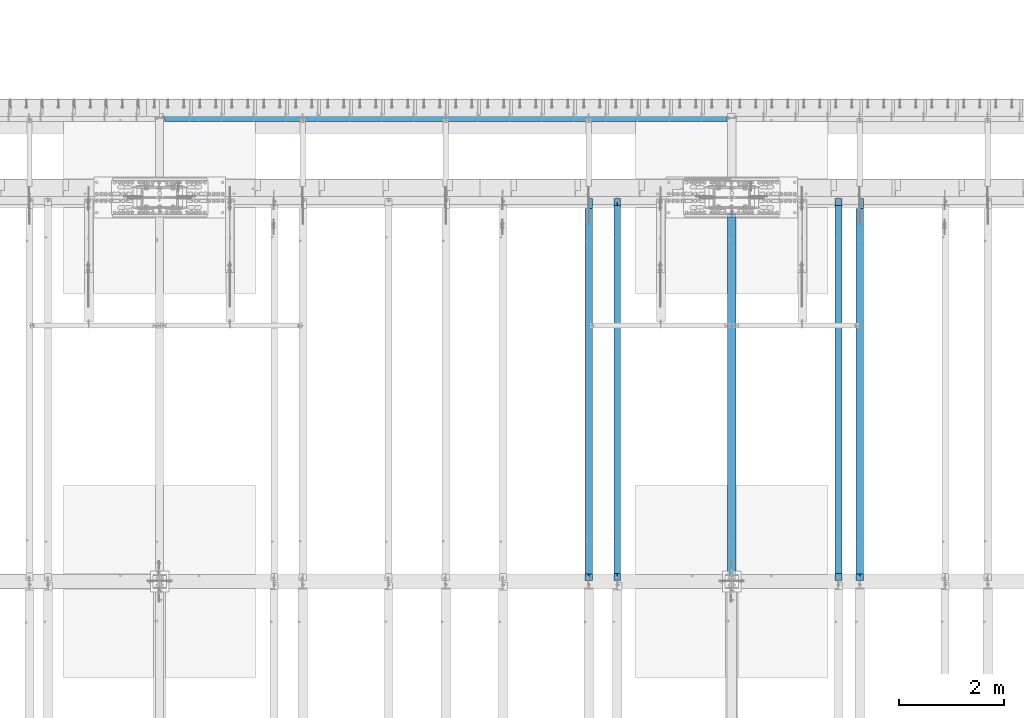
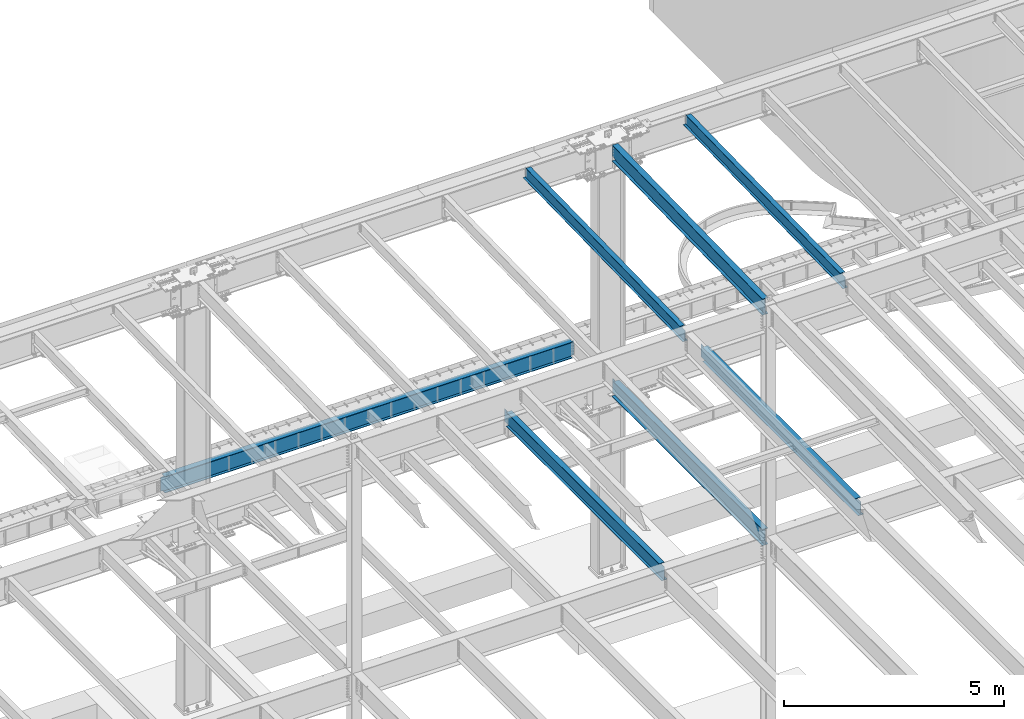
# One storey, part 1131 of 1763: 7 beams, 7 elements without a shape of their own.
"""IFC2X3 building model written with IfcOpenShell, lengths in millimetres."""

from ifc_helpers import new_model, si_unit, frame, origin_with_axes, place, context, subcontext, project, spatial, faceted_brep, material, type_object, element, aggregate, save


model = new_model("IFC2X3")

# Units and contexts
model_context = context("Model", 3, precision=1e-05, world=origin_with_axes())
body_context = subcontext(model_context, "Body", "Model", "MODEL_VIEW")
ifc_project = project(units=[si_unit("LENGTHUNIT", "METRE", prefix="MILLI"), si_unit("AREAUNIT", "SQUARE_METRE"), si_unit("VOLUMEUNIT", "CUBIC_METRE"), si_unit("MASSUNIT", "GRAM", prefix="KILO"), si_unit("TIMEUNIT", "SECOND"), si_unit("PLANEANGLEUNIT", "RADIAN"), si_unit("SOLIDANGLEUNIT", "STERADIAN"), si_unit("THERMODYNAMICTEMPERATUREUNIT", "DEGREE_CELSIUS"), si_unit("LUMINOUSINTENSITYUNIT", "LUMEN")], contexts=[model_context])

# Site, building, storey
site_placement = place(None, origin_with_axes())
site = spatial("IfcSite", under=ifc_project, at=site_placement, CompositionType="ELEMENT")
building_placement = place(site_placement, origin_with_axes())
building = spatial("IfcBuilding", under=site, at=building_placement, Name="Undefined", CompositionType="ELEMENT")
storey_placement = place(building_placement, origin_with_axes())
storey = spatial("IfcBuildingStorey", under=building, at=storey_placement, Name="Undefined", CompositionType="ELEMENT", Elevation=0.0)

# Assembly, beam
assembly_1_placement = place(storey_placement, origin_with_axes())
assembly_1 = element("IfcElementAssembly", 1, at=assembly_1_placement, inside=storey, Name="BEAM", AssemblyPlace="NOTDEFINED", PredefinedType="RIGID_FRAME")
ifc_material = material(Name="STEEL/A992")
beam_type_1 = type_object("IfcBeamType", Name="W16X26", PredefinedType="NOTDEFINED")
beam_1_placement = place(assembly_1_placement, frame((-59156.0372736983, 44805.6, 4994.275), z_axis=(0.0, 0.0, 1.0), x_axis=(0.0, 1.0, 0.0)))
beam_1 = element("IfcBeam", 2, at=beam_1_placement, type_object=beam_type_1, material=ifc_material, Name="BEAM", ObjectType="W16X26", context=body_context, shape_type="Brep", body=[
    faceted_brep([(7104.06248869727, 3.17500000000291, -190.5), (7104.06248869734, 3.17487653380522, -200.025), (7104.06247902929, 69.8499999999985, -200.025), (7104.06247902929, 69.8499999999985, -190.5), (7294.5625, 3.17500000000291, -190.5), (7294.5625, 3.17490415680368, -200.025), (146.04999924302, 3.17499999999927, 190.5), (146.04999924302, 69.8499999999985, 190.5), (7104.0625, 69.8499999999985, 190.5), (7104.0625, 3.17500000000291, 190.5), (146.04999943226, -69.8499999999985, 200.025), (146.04999943226, 69.8499999999985, 200.025), (146.04999943226, 3.17500000000291, 180.715001487731), (146.04999943226, -3.17500000000291, 180.715001487731), (146.04999924302, -3.17499999999927, 190.5), (146.04999924302, -69.8499999999985, 190.5), (145.083269509669, 3.17500000000291, 175.854921969685), (145.083269509669, -3.17500000000291, 175.854921969685), (142.330255609195, 3.17500000000291, 171.734745501532), (142.330255609195, -3.17500000000291, 171.734745501532), (138.210079141041, 3.17500000000291, 168.981731601053), (138.210079141041, -3.17500000000291, 168.981731601053), (133.349999622995, 3.17500000000291, 168.015001678466), (133.349999622995, -3.17500000000291, 168.015001678466), (19.0499999999956, 3.17500000000291, 168.015001678466), (19.0499999999956, -3.17500000000291, 168.015001678466), (19.0499999999956, 3.17499999999927, -190.5), (19.0499999999956, 69.8499999999985, -190.5), (19.0499999999956, 69.8499999999985, -200.025), (19.0499999999956, -69.8499999999985, -200.025), (19.0499999999956, -69.8499999999985, -190.5), (19.0499999999956, -3.17499999999927, -190.5), (7294.5625, -69.8499999999985, -200.025), (7294.5625, -69.8499999999985, -190.5), (7294.5625, -3.17500000000291, -190.5), (7111.90242029122, -3.17500000000291, 156.541729922587), (7107.78224382307, -3.17500000000291, 159.294743823066), (7105.02922992258, -3.17500000000291, 163.414920291219), (7104.0625, -3.17500000000291, 168.274999809265), (7104.0625, -3.17500000000291, 190.5), (7294.5625, -3.17500000000291, 155.575), (7116.76249980927, -3.17500000000291, 155.575), (7104.0625, -69.8499999999985, 190.5), (7104.0625, -69.8499999999985, 200.025), (7104.0625, 69.8499999999985, 200.025), (7104.0625, 3.17500000000291, 168.274999809265), (7105.02922992258, 3.17500000000291, 163.414920291219), (7107.78224382307, 3.17500000000291, 159.294743823066), (7111.90242029122, 3.17500000000291, 156.541729922587), (7116.76249980927, 3.17500000000291, 155.575), (7294.5625, 3.17500000000291, 155.575), (7294.5625, 3.17500000000291, -184.976846570121)], [[[0, 1, 2, 3]], [[4, 5, 1, 0]], [[6, 7, 8, 9]], [[10, 11, 7, 6, 12, 13, 14, 15]], [[13, 12, 16, 17]], [[17, 16, 18, 19]], [[19, 18, 20, 21]], [[21, 20, 22, 23]], [[23, 22, 24, 25]], [[26, 27, 28, 29, 30, 31, 25, 24]], [[30, 29, 32, 33]], [[31, 30, 33, 34]], [[35, 36, 37, 38, 39, 14, 13, 17, 19, 21, 23, 25, 31, 34, 40, 41]], [[15, 14, 39, 42]], [[10, 15, 42, 43]], [[11, 10, 43, 44]], [[7, 11, 44, 8]], [[43, 42, 39, 38, 45, 9, 8, 44]], [[37, 46, 45, 38]], [[36, 47, 46, 37]], [[35, 48, 47, 36]], [[41, 49, 48, 35]], [[40, 50, 49, 41]], [[51, 4, 0, 26, 24, 22, 20, 18, 16, 12, 6, 9, 45, 46, 47, 48, 49, 50]], [[27, 26, 0, 3]], [[28, 27, 3, 2]], [[32, 29, 28, 2, 1, 5]], [[51, 50, 40, 34, 33, 32, 5, 4]]]),
])
aggregate(assembly_1, [beam_1])

assembly_2_placement = place(storey_placement, origin_with_axes())
assembly_2 = element("IfcElementAssembly", 3, at=assembly_2_placement, inside=storey, Name="BEAM", AssemblyPlace="NOTDEFINED", PredefinedType="RIGID_FRAME")
beam_2_placement = place(assembly_2_placement, frame((-64318.5872736984, 44805.6, 4994.275), z_axis=(0.0, 0.0, 1.0), x_axis=(0.0, 1.0, 0.0)))
beam_2 = element("IfcBeam", 4, at=beam_2_placement, type_object=beam_type_1, material=ifc_material, Name="BEAM", ObjectType="W16X26", context=body_context, shape_type="Brep", body=[
    faceted_brep([(7104.06248869727, 3.17500000000291, -190.5), (7104.06248869734, 3.17487653380522, -200.025), (7104.06247902929, 69.8499999999985, -200.025), (7104.06247902929, 69.8499999999985, -190.5), (7294.5625, 3.17500000000291, -190.5), (7294.5625, 3.17490415680368, -200.025), (146.04999924302, 3.17499999999927, 190.5), (146.04999924302, 69.8499999999985, 190.5), (7104.0625, 69.8499999999985, 190.5), (7104.0625, 3.17500000000291, 190.5), (146.04999943226, -69.8499999999985, 200.025), (146.04999943226, 69.8499999999985, 200.025), (146.04999943226, 3.17500000000291, 180.715001487731), (146.04999943226, -3.17500000000291, 180.715001487731), (146.04999924302, -3.17499999999927, 190.5), (146.04999924302, -69.8499999999985, 190.5), (145.083269509669, 3.17500000000291, 175.854921969685), (145.083269509669, -3.17500000000291, 175.854921969685), (142.330255609195, 3.17500000000291, 171.734745501532), (142.330255609195, -3.17500000000291, 171.734745501532), (138.210079141041, 3.17500000000291, 168.981731601053), (138.210079141041, -3.17500000000291, 168.981731601053), (133.349999622995, 3.17500000000291, 168.015001678466), (133.349999622995, -3.17500000000291, 168.015001678466), (19.0499999999956, 3.17500000000291, 168.015001678466), (19.0499999999956, -3.17500000000291, 168.015001678466), (19.0499999999956, 3.17499999999927, -190.5), (19.0499999999956, 69.8499999999985, -190.5), (19.0499999999956, 69.8499999999985, -200.025), (19.0499999999956, -69.8499999999985, -200.025), (19.0499999999956, -69.8499999999985, -190.5), (19.0499999999956, -3.17499999999927, -190.5), (7294.5625, -69.8499999999985, -200.025), (7294.5625, -69.8499999999985, -190.5), (7294.5625, -3.17500000000291, -190.5), (7111.90242029122, -3.17500000000291, 156.541729922587), (7107.78224382307, -3.17500000000291, 159.294743823066), (7105.02922992258, -3.17500000000291, 163.414920291219), (7104.0625, -3.17500000000291, 168.274999809265), (7104.0625, -3.17500000000291, 190.5), (7294.5625, -3.17500000000291, 155.575), (7116.76249980927, -3.17500000000291, 155.575), (7104.0625, -69.8499999999985, 190.5), (7104.0625, -69.8499999999985, 200.025), (7104.0625, 69.8499999999985, 200.025), (7104.0625, 3.17500000000291, 168.274999809265), (7105.02922992258, 3.17500000000291, 163.414920291219), (7107.78224382307, 3.17500000000291, 159.294743823066), (7111.90242029122, 3.17500000000291, 156.541729922587), (7116.76249980927, 3.17500000000291, 155.575), (7294.5625, 3.17500000000291, 155.575), (7294.5625, 3.17500000000291, -184.976846570121)], [[[0, 1, 2, 3]], [[4, 5, 1, 0]], [[6, 7, 8, 9]], [[10, 11, 7, 6, 12, 13, 14, 15]], [[13, 12, 16, 17]], [[17, 16, 18, 19]], [[19, 18, 20, 21]], [[21, 20, 22, 23]], [[23, 22, 24, 25]], [[26, 27, 28, 29, 30, 31, 25, 24]], [[30, 29, 32, 33]], [[31, 30, 33, 34]], [[35, 36, 37, 38, 39, 14, 13, 17, 19, 21, 23, 25, 31, 34, 40, 41]], [[15, 14, 39, 42]], [[10, 15, 42, 43]], [[11, 10, 43, 44]], [[7, 11, 44, 8]], [[43, 42, 39, 38, 45, 9, 8, 44]], [[37, 46, 45, 38]], [[36, 47, 46, 37]], [[35, 48, 47, 36]], [[41, 49, 48, 35]], [[40, 50, 49, 41]], [[51, 4, 0, 26, 24, 22, 20, 18, 16, 12, 6, 9, 45, 46, 47, 48, 49, 50]], [[27, 26, 0, 3]], [[28, 27, 3, 2]], [[32, 29, 28, 2, 1, 5]], [[51, 50, 40, 34, 33, 32, 5, 4]]]),
])
aggregate(assembly_2, [beam_2])

assembly_3_placement = place(storey_placement, origin_with_axes())
assembly_3 = element("IfcElementAssembly", 5, at=assembly_3_placement, inside=storey, Name="BEAM", AssemblyPlace="NOTDEFINED", PredefinedType="RIGID_FRAME")
beam_type_2 = type_object("IfcBeamType", Name="W14X22", PredefinedType="NOTDEFINED")
beam_3_placement = place(assembly_3_placement, frame((-59562.4372736983, 44809.2121579121, 11421.5633921212), z_axis=(0.0, -0.0206852279954837, 0.999786037781472), x_axis=(0.0, 0.999786037781472, 0.0206852279954825)))
beam_3 = element("IfcBeam", 6, at=beam_3_placement, type_object=beam_type_2, material=ifc_material, Name="BEAM", ObjectType="W14X22", context=body_context, shape_type="Brep", body=[
    faceted_brep([(136.091146049795, -3.17500000000291, 123.565001678358), (136.091146049795, 3.17500000000291, 123.565001678358), (17.9976630864912, 3.17500000000291, 123.56500167838), (17.9976630864912, -3.17500000000291, 123.56500167838), (140.951225567893, -3.17500000000291, 124.531731600942), (140.951225567893, 3.17500000000291, 124.531731600942), (145.071402036083, -3.17500000000291, 127.284745501414), (145.071402036083, 3.17500000000291, 127.284745501414), (147.824415936586, -3.17500000000291, 131.404921969557), (147.824415936586, 3.17500000000291, 131.404921969557), (148.791145859177, -3.17500000000291, 136.265001487593), (148.791145859177, 3.17500000000291, 136.265001487593), (148.79114585917, -63.5, 174.624999999827), (148.79114585917, 63.5, 174.624999999827), (148.791145859177, 63.5, 166.687499999833), (148.791145859177, 3.17500000000291, 166.687499999833), (148.791145859177, -3.17500000000291, 166.687499999833), (148.791145859177, -63.5, 166.687499999833), (11.9924390219312, -3.17500000000291, -166.687499999878), (11.9924390219312, -63.5, -166.687499999878), (7289.06195724197, -63.5, -166.687500001812), (7289.06195724197, -3.17500000000291, -166.687500001812), (11.8282148869548, -63.5, -174.624999999871), (7288.89773310699, -63.5, -174.625000001806), (11.8282148869548, 63.5, -174.624999999871), (7288.89773310699, 63.5, -174.625000001806), (11.9924390219312, 63.5, -166.687499999878), (7289.06195724197, 63.5, -166.687500001812), (11.9924390219312, 3.17500000000291, -166.687499999878), (7289.06195724197, 3.17500000000291, -166.687500001812), (7294.93580191941, 3.17500000000291, 117.21499785159), (7294.93580191941, -3.17500000000291, 117.21499785159), (7178.21066392501, 3.17500000000291, 117.214997851612), (7178.21066392501, -3.17500000000291, 117.214997851612), (7173.35058440694, 3.17500000000291, 118.181727774199), (7173.35058440694, -3.17500000000291, 118.181727774199), (7169.23040793875, 3.17500000000291, 120.934741674671), (7169.23040793875, -3.17500000000291, 120.934741674671), (7166.47739403824, 3.17500000000291, 125.054918142816), (7166.47739403824, -3.17500000000291, 125.054918142816), (7165.51066411565, 3.17500000000291, 129.91499766085), (7165.51066411565, -3.17500000000291, 129.91499766085), (7165.51066411565, -63.5, 174.624999997965), (7165.51066411565, -63.5, 166.68749999797), (7165.51066411565, -3.17500000000291, 166.68749999797), (7165.51066411565, 3.17500000000291, 166.68749999797), (7165.51066411565, 63.5, 166.68749999797), (7165.51066411565, 63.5, 174.624999997965)], [[[0, 1, 2, 3]], [[4, 5, 1, 0]], [[6, 7, 5, 4]], [[8, 9, 7, 6]], [[10, 11, 9, 8]], [[12, 13, 14, 15, 11, 10, 16, 17]], [[18, 19, 20, 21]], [[19, 22, 23, 20]], [[22, 24, 25, 23]], [[24, 26, 27, 25]], [[26, 28, 29, 27]], [[21, 20, 23, 25, 27, 29, 30, 31]], [[31, 30, 32, 33]], [[33, 32, 34, 35]], [[35, 34, 36, 37]], [[37, 36, 38, 39]], [[39, 38, 40, 41]], [[42, 43, 44, 41, 40, 45, 46, 47]], [[43, 42, 12, 17]], [[44, 43, 17, 16]], [[8, 6, 4, 0, 3, 18, 21, 31, 33, 35, 37, 39, 41, 44, 16, 10]], [[28, 26, 24, 22, 19, 18, 3, 2]], [[45, 40, 38, 36, 34, 32, 30, 29, 28, 2, 1, 5, 7, 9, 11, 15]], [[46, 45, 15, 14]], [[47, 46, 14, 13]], [[42, 47, 13, 12]]]),
])
aggregate(assembly_3, [beam_3])

assembly_4_placement = place(storey_placement, origin_with_axes())
assembly_4 = element("IfcElementAssembly", 7, at=assembly_4_placement, inside=storey, Name="BEAM", AssemblyPlace="NOTDEFINED", PredefinedType="RIGID_FRAME")
beam_4_placement = place(assembly_4_placement, frame((-63773.7572736983, 44809.2121579121, 11421.5633921212), z_axis=(0.0, -0.0206852279954837, 0.999786037781472), x_axis=(0.0, 0.999786037781472, 0.0206852279954825)))
beam_4 = element("IfcBeam", 8, at=beam_4_placement, type_object=beam_type_2, material=ifc_material, Name="BEAM", ObjectType="W14X22", context=body_context, shape_type="Brep", body=[
    faceted_brep([(136.091146049795, -3.17500000000291, 123.565001678358), (136.091146049795, 3.17500000000291, 123.565001678358), (17.9976630864912, 3.17500000000291, 123.56500167838), (17.9976630864912, -3.17500000000291, 123.56500167838), (140.951225567893, -3.17500000000291, 124.531731600942), (140.951225567893, 3.17500000000291, 124.531731600942), (145.071402036083, -3.17500000000291, 127.284745501414), (145.071402036083, 3.17500000000291, 127.284745501414), (147.824415936586, -3.17500000000291, 131.404921969557), (147.824415936586, 3.17500000000291, 131.404921969557), (148.791145859177, -3.17500000000291, 136.265001487593), (148.791145859177, 3.17500000000291, 136.265001487593), (148.79114585917, -63.5, 174.624999999827), (148.79114585917, 63.5, 174.624999999827), (148.791145859177, 63.5, 166.687499999833), (148.791145859177, 3.17500000000291, 166.687499999833), (148.791145859177, -3.17500000000291, 166.687499999833), (148.791145859177, -63.5, 166.687499999833), (11.9924390219312, -3.17500000000291, -166.687499999878), (11.9924390219312, -63.5, -166.687499999878), (7289.06195724197, -63.5, -166.687500001812), (7289.06195724197, -3.17500000000291, -166.687500001812), (11.8282148869548, -63.5, -174.624999999871), (7288.89773310699, -63.5, -174.625000001806), (11.8282148869548, 63.5, -174.624999999871), (7288.89773310699, 63.5, -174.625000001806), (11.9924390219312, 63.5, -166.687499999878), (7289.06195724197, 63.5, -166.687500001812), (11.9924390219312, 3.17500000000291, -166.687499999878), (7289.06195724197, 3.17500000000291, -166.687500001812), (7294.93580191941, 3.17500000000291, 117.21499785159), (7294.93580191941, -3.17500000000291, 117.21499785159), (7178.21066392501, 3.17500000000291, 117.214997851612), (7178.21066392501, -3.17500000000291, 117.214997851612), (7173.35058440694, 3.17500000000291, 118.181727774199), (7173.35058440694, -3.17500000000291, 118.181727774199), (7169.23040793875, 3.17500000000291, 120.934741674671), (7169.23040793875, -3.17500000000291, 120.934741674671), (7166.47739403824, 3.17500000000291, 125.054918142816), (7166.47739403824, -3.17500000000291, 125.054918142816), (7165.51066411565, 3.17500000000291, 129.91499766085), (7165.51066411565, -3.17500000000291, 129.91499766085), (7165.51066411565, -63.5, 174.624999997965), (7165.51066411565, -63.5, 166.68749999797), (7165.51066411565, -3.17500000000291, 166.68749999797), (7165.51066411565, 3.17500000000291, 166.68749999797), (7165.51066411565, 63.5, 166.68749999797), (7165.51066411565, 63.5, 174.624999997965)], [[[0, 1, 2, 3]], [[4, 5, 1, 0]], [[6, 7, 5, 4]], [[8, 9, 7, 6]], [[10, 11, 9, 8]], [[12, 13, 14, 15, 11, 10, 16, 17]], [[18, 19, 20, 21]], [[19, 22, 23, 20]], [[22, 24, 25, 23]], [[24, 26, 27, 25]], [[26, 28, 29, 27]], [[21, 20, 23, 25, 27, 29, 30, 31]], [[31, 30, 32, 33]], [[33, 32, 34, 35]], [[35, 34, 36, 37]], [[37, 36, 38, 39]], [[39, 38, 40, 41]], [[42, 43, 44, 41, 40, 45, 46, 47]], [[43, 42, 12, 17]], [[44, 43, 17, 16]], [[8, 6, 4, 0, 3, 18, 21, 31, 33, 35, 37, 39, 41, 44, 16, 10]], [[28, 26, 24, 22, 19, 18, 3, 2]], [[45, 40, 38, 36, 34, 32, 30, 29, 28, 2, 1, 5, 7, 9, 11, 15]], [[46, 45, 15, 14]], [[47, 46, 14, 13]], [[42, 47, 13, 12]]]),
])
aggregate(assembly_4, [beam_4])

assembly_5_placement = place(storey_placement, origin_with_axes())
assembly_5 = element("IfcElementAssembly", 9, at=assembly_5_placement, inside=storey, Name="BEAM", AssemblyPlace="NOTDEFINED", PredefinedType="RIGID_FRAME")
beam_type_3 = type_object("IfcBeamType", Name="W18X35", PredefinedType="NOTDEFINED")
beam_5_placement = place(assembly_5_placement, frame((-61594.4372736983, 44810.2629674943, 11370.7742614019), z_axis=(0.0, -0.0206852279954837, 0.999786037781472), x_axis=(0.0, 0.999786037781472, 0.0206852279954825)))
beam_5 = element("IfcBeam", 10, at=beam_5_placement, type_object=beam_type_3, material=ifc_material, Name="BEAM", ObjectType="W18X35", context=body_context, shape_type="Brep", body=[
    faceted_brep([(6981.85534172427, -3.96875, -214.312500001693), (6981.85534172427, -76.1999999999971, -214.312500001693), (6981.85534172427, -76.1999999999971, -225.425000001685), (6981.85534172427, 76.1999999999971, -225.425000001685), (6981.85534172427, 76.1999999999971, -214.312500001693), (6981.85534172427, 3.96875, -214.312500001693), (6981.85534172429, 3.96875, -200.284999820729), (6981.85534172429, -3.96875, -200.284999820729), (6982.82207164688, 3.96875, -195.424920302696), (6982.82207164688, -3.96875, -195.424920302696), (6985.57508554738, 3.96875, -191.304743834553), (6985.57508554738, -3.96875, -191.304743834553), (6989.69526201557, 3.96875, -188.551729934081), (6989.69526201557, -3.96875, -188.551729934081), (6994.55534153366, 3.96875, -187.585000011497), (6994.55534153366, -3.96875, -187.585000011497), (7092.27427279067, -3.96875, -187.585000011552), (7092.27427279067, 3.96875, -187.585000011552), (144.263502213013, 3.96875, 214.312499999811), (144.263502213013, 76.1999999999971, 214.312499999811), (6981.85534172432, 76.1999999999971, 214.312499997985), (6981.85534172432, 3.96875, 214.312499997985), (135.16548513544, -76.1999999999971, -225.424999999856), (135.395398924404, -76.1999999999971, -214.312499999864), (135.395398924404, -3.96875, -214.312499999864), (144.263502213013, -3.96875, 214.312499999811), (144.263502213013, -76.1999999999971, 214.312499999811), (144.493416001977, -76.1999999999971, 225.424999999803), (144.493416001977, 76.1999999999971, 225.424999999803), (135.395398924404, 3.96875, -214.312499999864), (135.395398924404, 76.1999999999971, -214.312499999864), (135.16548513544, 76.1999999999971, -225.424999999856), (6981.85534172432, -3.96875, 214.312499997985), (6981.85534172432, -76.1999999999971, 214.312499997985), (6981.85534172433, -76.1999999999971, 225.424999997977), (6981.85534172433, 76.1999999999971, 225.424999997977), (6981.85534172432, -3.96875, 199.765001475287), (6981.85534172432, 3.96875, 199.765001475287), (6982.82207164692, -3.96875, 194.904921957252), (6982.82207164692, 3.96875, 194.904921957252), (6985.57508554743, -3.96875, 190.784745489109), (6985.57508554743, 3.96875, 190.784745489109), (6989.69526201561, -3.96875, 188.031731588633), (6989.69526201561, 3.96875, 188.031731588633), (6994.55534153371, -3.96875, 187.065001666047), (6994.55534153371, 3.96875, 187.065001666047), (7100.02565199621, -3.96875, 187.065001666027), (7100.02565199621, 3.96875, 187.065001666027)], [[[0, 1, 2, 3, 4, 5, 6, 7]], [[7, 6, 8, 9]], [[9, 8, 10, 11]], [[11, 10, 12, 13]], [[13, 12, 14, 15]], [[16, 15, 14, 17]], [[18, 19, 20, 21]], [[22, 23, 24, 25, 26, 27, 28, 19, 18, 29, 30, 31]], [[26, 25, 32, 33]], [[27, 26, 33, 34]], [[28, 27, 34, 35]], [[19, 28, 35, 20]], [[34, 33, 32, 36, 37, 21, 20, 35]], [[38, 39, 37, 36]], [[40, 41, 39, 38]], [[42, 43, 41, 40]], [[44, 45, 43, 42]], [[46, 47, 45, 44]], [[47, 46, 16, 17]], [[12, 10, 8, 6, 5, 29, 18, 21, 37, 39, 41, 43, 45, 47, 17, 14]], [[30, 29, 5, 4]], [[31, 30, 4, 3]], [[22, 31, 3, 2]], [[23, 22, 2, 1]], [[24, 23, 1, 0]], [[46, 44, 42, 40, 38, 36, 32, 25, 24, 0, 7, 9, 11, 13, 15, 16]]]),
])
aggregate(assembly_5, [beam_5])

assembly_6_placement = place(storey_placement, origin_with_axes())
assembly_6 = element("IfcElementAssembly", 11, at=assembly_6_placement, inside=storey, Name="BEAM", AssemblyPlace="NOTDEFINED", PredefinedType="RIGID_FRAME")
beam_type_4 = type_object("IfcBeamType", Name="W18X40", PredefinedType="NOTDEFINED")
beam_6_placement = place(assembly_6_placement, frame((-72491.0372736984, 53644.8, 4967.2875), z_axis=(0.0, 0.0, 1.0), x_axis=(1.0, 0.0, 0.0)))
beam_6 = element("IfcBeam", 12, at=beam_6_placement, type_object=beam_type_4, material=ifc_material, Name="BEAM", ObjectType="W18X40", context=body_context, shape_type="Brep", body=[
    faceted_brep([(10806.90625, -3.96875, -214.3125), (10806.90625, -76.1999999999971, -214.3125), (10806.90625, -76.1999999999971, -227.0125), (10806.90625, 76.1999999999971, -227.0125), (10806.90625, 76.1999999999971, -214.3125), (10806.90625, 3.96875, -214.3125), (10806.90625, 3.96875, -208.222499809265), (10806.90625, -3.96875, -208.222499809265), (10807.8729799226, 3.96875, -203.36242029122), (10807.8729799226, -3.96875, -203.36242029122), (10810.6259938231, 3.96875, -199.242243823066), (10810.6259938231, -3.96875, -199.242243823066), (10814.7461702912, 3.96875, -196.489229922588), (10814.7461702912, -3.96875, -196.489229922588), (10819.6062498093, 3.96875, -195.5225), (10819.6062498093, -3.96875, -195.5225), (10879.93125, -3.96875, -195.5225), (10879.93125, 3.96875, -195.5225), (89.6937500000058, 3.96875, 214.3125), (89.6937500000058, 76.1999999999971, 214.3125), (10806.90625, 76.1999999999971, 214.3125), (10806.90625, 3.96875, 214.3125), (89.6937500000058, -3.96875, -208.222499809265), (89.6937500000058, 3.96875, -208.222499809265), (89.6937500000058, 3.96875, -214.3125), (89.6937500000058, 76.1999999999971, -214.3125), (89.6937500000058, 76.1999999999971, -227.0125), (89.6937500000058, -76.1999999999971, -227.0125), (89.6937500000058, -76.1999999999971, -214.3125), (89.6937500000058, -3.96875, -214.3125), (88.7270200774146, -3.96875, -203.36242029122), (88.7270200774146, 3.96875, -203.36242029122), (85.9740061769407, -3.96875, -199.242243823066), (85.9740061769407, 3.96875, -199.242243823066), (81.8538297087871, -3.96875, -196.489229922588), (81.8538297087871, 3.96875, -196.489229922588), (76.9937501907407, -3.96875, -195.5225), (76.9937501907407, 3.96875, -195.5225), (16.6687499999971, -3.96875, -195.5225), (16.6687499999971, 3.96875, -195.5225), (16.6687499999971, -3.96875, 195.002501678467), (16.6687499999971, 3.96875, 195.002501678467), (76.9937501907407, -3.96875, 195.002501678467), (76.9937501907407, 3.96875, 195.002501678467), (81.8538297087871, -3.96875, 195.969231601054), (81.8538297087871, 3.96875, 195.969231601054), (85.9740061769407, -3.96875, 198.722245501533), (85.9740061769407, 3.96875, 198.722245501533), (88.7270200774146, -3.96875, 202.842421969686), (88.7270200774146, 3.96875, 202.842421969686), (89.6937500000058, -3.96875, 207.702501487732), (89.6937500000058, 3.96875, 207.702501487732), (89.6937500000058, -76.1999999999971, 227.0125), (89.6937500000058, 76.1999999999971, 227.0125), (89.6937500000058, -3.96875, 214.3125), (89.6937500000058, -76.1999999999971, 214.3125), (10806.90625, -3.96875, 214.3125), (10806.90625, -76.1999999999971, 214.3125), (10806.90625, -76.1999999999971, 227.0125), (10806.90625, 76.1999999999971, 227.0125), (10806.90625, -3.96875, 207.702501487732), (10806.90625, 3.96875, 207.702501487732), (10807.8729799226, -3.96875, 202.842421969686), (10807.8729799226, 3.96875, 202.842421969686), (10810.6259938231, -3.96875, 198.722245501533), (10810.6259938231, 3.96875, 198.722245501533), (10814.7461702912, -3.96875, 195.969231601054), (10814.7461702912, 3.96875, 195.969231601054), (10819.6062498093, -3.96875, 195.002501678467), (10819.6062498093, 3.96875, 195.002501678467), (10879.93125, -3.96875, 195.002501678467), (10879.93125, 3.96875, 195.002501678467)], [[[0, 1, 2, 3, 4, 5, 6, 7]], [[7, 6, 8, 9]], [[9, 8, 10, 11]], [[11, 10, 12, 13]], [[13, 12, 14, 15]], [[16, 15, 14, 17]], [[18, 19, 20, 21]], [[22, 23, 24, 25, 26, 27, 28, 29]], [[30, 31, 23, 22]], [[32, 33, 31, 30]], [[34, 35, 33, 32]], [[36, 37, 35, 34]], [[38, 39, 37, 36]], [[40, 41, 39, 38]], [[42, 43, 41, 40]], [[44, 45, 43, 42]], [[46, 47, 45, 44]], [[48, 49, 47, 46]], [[50, 51, 49, 48]], [[52, 53, 19, 18, 51, 50, 54, 55]], [[55, 54, 56, 57]], [[52, 55, 57, 58]], [[53, 52, 58, 59]], [[19, 53, 59, 20]], [[58, 57, 56, 60, 61, 21, 20, 59]], [[62, 63, 61, 60]], [[64, 65, 63, 62]], [[66, 67, 65, 64]], [[68, 69, 67, 66]], [[70, 71, 69, 68]], [[71, 70, 16, 17]], [[12, 10, 8, 6, 5, 24, 23, 31, 33, 35, 37, 39, 41, 43, 45, 47, 49, 51, 18, 21, 61, 63, 65, 67, 69, 71, 17, 14]], [[25, 24, 5, 4]], [[26, 25, 4, 3]], [[27, 26, 3, 2]], [[28, 27, 2, 1]], [[29, 28, 1, 0]], [[70, 68, 66, 64, 62, 60, 56, 54, 50, 48, 46, 44, 42, 40, 38, 36, 34, 32, 30, 22, 29, 0, 7, 9, 11, 13, 15, 16]]]),
])
aggregate(assembly_6, [beam_6])

assembly_7_placement = place(storey_placement, origin_with_axes())
assembly_7 = element("IfcElementAssembly", 13, at=assembly_7_placement, inside=storey, Name="BEAM", AssemblyPlace="NOTDEFINED", PredefinedType="RIGID_FRAME")
beam_7_placement = place(assembly_7_placement, frame((-61594.4372736983, 44805.6, 4967.2875), z_axis=(0.0, 0.0, 1.0), x_axis=(0.0, 1.0, 0.0)))
beam_7 = element("IfcBeam", 14, at=beam_7_placement, type_object=beam_type_4, material=ifc_material, Name="BEAM", ObjectType="W18X40", context=body_context, shape_type="Brep", body=[
    faceted_brep([(6937.37498732733, -76.1999999999971, 214.3125), (6937.37498732733, -3.96875, 214.3125), (6937.60420254865, -3.96875, 213.91549911499), (6937.60420254865, 3.96875, 213.91549911499), (6937.37498732733, 3.96875, 214.3125), (6937.37498732733, 76.1999999999971, 214.3125), (6930.04242606437, 76.1999999999971, 227.0125), (6930.04242606437, -76.1999999999971, 227.0125), (144.462499999994, 76.1999999999971, -214.3125), (144.462499999994, 71.199821507762, -214.3125), (144.462499999994, 3.96875, -214.3125), (6999.89240878766, 3.96875, -214.3125), (6999.89240878766, 76.1999999999971, -214.3125), (6890.76589898111, -3.96875, 204.211830867132), (6890.76589898111, 3.96875, 204.211830867132), (6911.97500305174, 3.96875, 213.91549911499), (6911.97500305174, -3.96875, 213.91549911499), (6887.72798328583, -3.96875, 201.276913128712), (6887.72798328583, 3.96875, 201.276913128712), (6887.20337863325, -3.96875, 197.085557278698), (6887.20337863325, 3.96875, 197.085557278698), (6889.42422216828, -3.96875, 193.492434974088), (6889.42422216828, 3.96875, 193.492434974088), (6893.40779237872, -3.96875, 192.0875), (6893.40779237872, 3.96875, 192.0875), (7089.77499999998, -3.96875, 192.0875), (7089.77499999998, 3.96875, 192.0875), (7089.77499999998, -3.96875, -192.0875), (7089.77499999998, 3.96875, -192.0875), (6980.86678896075, -3.96875, -192.0875), (6980.86678896075, 3.96875, -192.0875), (6976.88321875031, -3.96875, -193.492434974089), (6976.88321875031, 3.96875, -193.492434974089), (6974.66237521528, -3.96875, -197.085557278698), (6974.66237521528, 3.96875, -197.085557278698), (6975.18697986786, -3.96875, -201.276913128712), (6975.18697986786, 3.96875, -201.276913128712), (6978.22489556314, -3.96875, -204.211830867132), (6978.22489556314, 3.96875, -204.211830867132), (6999.43399963377, -3.96875, -213.91549911499), (6999.43399963377, 3.96875, -213.91549911499), (144.462499999994, -76.1999999999971, -227.0125), (144.462499999994, -14.2685700086731, -227.0125), (144.462499999994, -5.73107306084421, -227.0125), (144.462499999994, 71.2001784793538, -227.0125), (144.462499999994, 76.1999999999971, -227.0125), (7007.22459707105, 76.1999999999971, -227.0125), (7007.22459707105, -76.1999999999971, -227.0125), (144.462499999994, -76.1999999999971, -214.3125), (6999.89240878766, -76.1999999999971, -214.3125), (144.462499999994, -3.96875, -214.3125), (144.462499999994, -5.73143003243604, -214.3125), (144.462499999994, -14.268926980265, -214.3125), (6999.89240878766, -3.96875, -214.3125), (144.462499999994, -3.96875, -205.614753375452), (144.462499999994, -3.96875, 214.3125), (144.462499999994, -76.1999999999971, 214.3125), (144.462499999994, -76.1999999999971, 227.0125), (144.462499999994, 76.1999999999971, 227.0125), (144.462499999994, 76.1999999999971, 214.3125), (144.462499999994, 3.96875, 214.3125), (144.462499999994, 3.96875, -205.614530268201)], [[[0, 1, 2, 3, 4, 5, 6, 7]], [[8, 9, 10, 11, 12]], [[13, 14, 15, 16]], [[17, 18, 14, 13]], [[19, 20, 18, 17]], [[21, 22, 20, 19]], [[23, 24, 22, 21]], [[24, 23, 25, 26]], [[25, 27, 28, 26]], [[29, 30, 28, 27]], [[31, 32, 30, 29]], [[33, 34, 32, 31]], [[35, 36, 34, 33]], [[37, 38, 36, 35]], [[38, 37, 39, 40]], [[41, 42, 43, 44, 45, 46, 47]], [[48, 41, 47, 49]], [[50, 51, 52, 48, 49, 53]], [[47, 46, 12, 11, 40, 39, 53, 49]], [[45, 8, 12, 46]], [[44, 43, 42, 41, 48, 52, 51, 50, 54, 55, 56, 57, 58, 59, 60, 61, 10, 9, 8, 45]], [[57, 56, 0, 7]], [[58, 57, 7, 6]], [[59, 58, 6, 5]], [[60, 59, 5, 4]], [[15, 14, 18, 20, 22, 24, 26, 28, 30, 32, 34, 36, 38, 40, 11, 10, 61, 60, 4, 3]], [[16, 15, 3, 2]], [[55, 54, 50, 53, 39, 37, 35, 33, 31, 29, 27, 25, 23, 21, 19, 17, 13, 16, 2, 1]], [[56, 55, 1, 0]]]),
])
aggregate(assembly_7, [beam_7])

save(model, "model.ifc")
